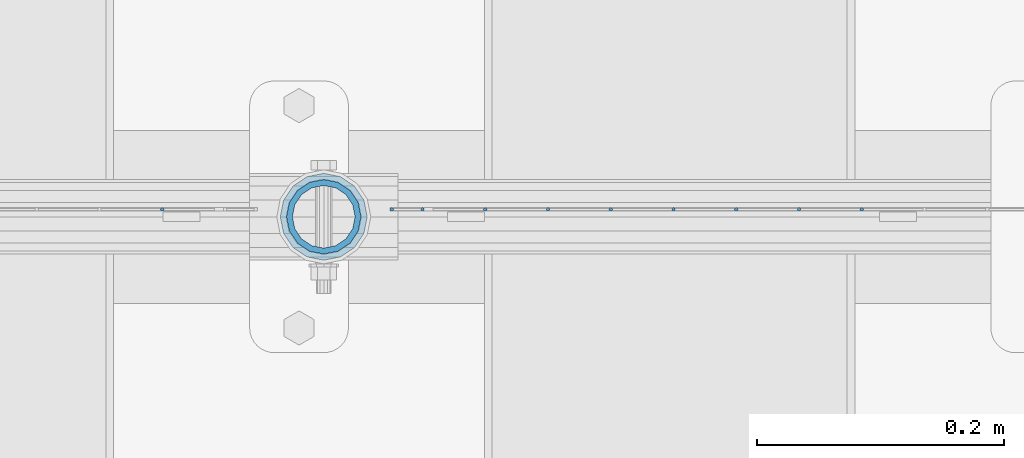
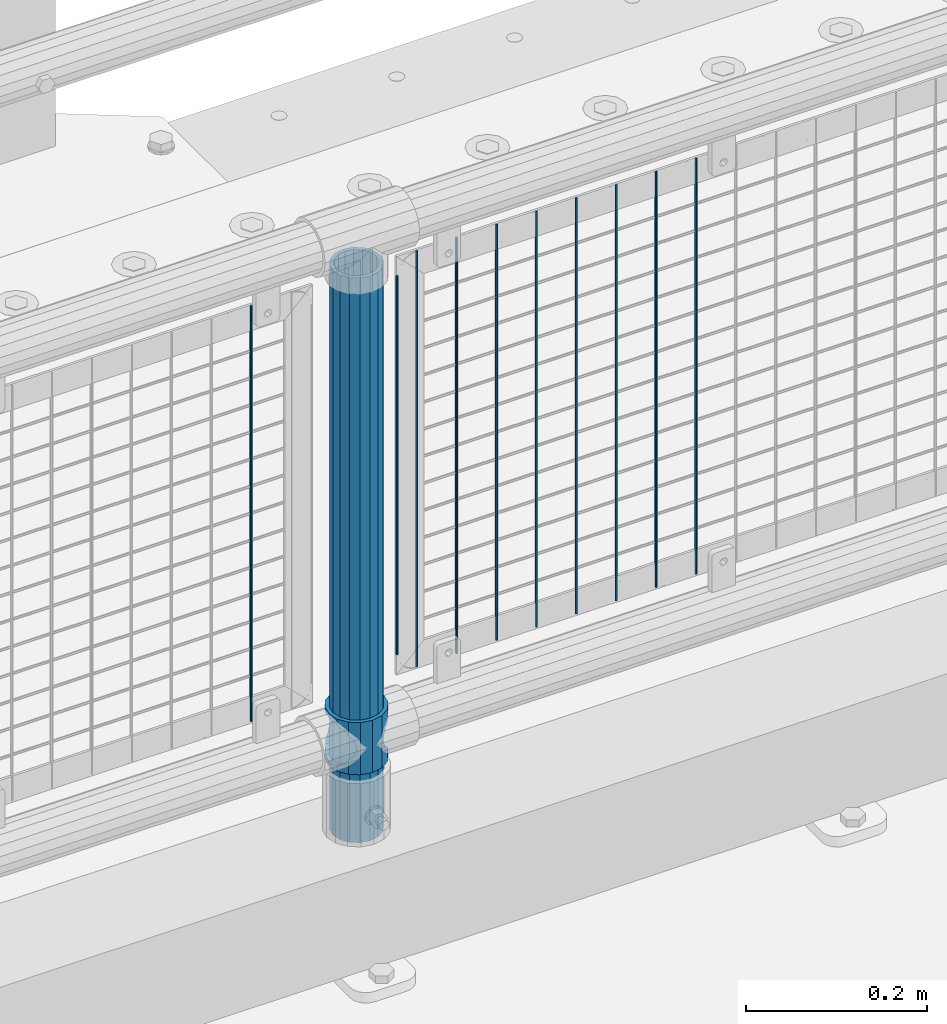
# One storey, part 72 of 242: 12 columns.
"""IFC2X3 building model written with IfcOpenShell, lengths in millimetres."""

from ifc_helpers import new_model, si_unit, frame, origin_with_axes, place, context, subcontext, project, spatial, faceted_brep, material, type_object, element, save


model = new_model("IFC2X3")

# Units and contexts
model_context = context("Model", 3, precision=1e-05, world=origin_with_axes())
body_context = subcontext(model_context, "Body", "Model", "MODEL_VIEW")
ifc_project = project(units=[si_unit("LENGTHUNIT", "METRE", prefix="MILLI"), si_unit("AREAUNIT", "SQUARE_METRE"), si_unit("VOLUMEUNIT", "CUBIC_METRE"), si_unit("MASSUNIT", "GRAM", prefix="KILO"), si_unit("TIMEUNIT", "SECOND"), si_unit("PLANEANGLEUNIT", "RADIAN"), si_unit("SOLIDANGLEUNIT", "STERADIAN"), si_unit("THERMODYNAMICTEMPERATUREUNIT", "DEGREE_CELSIUS"), si_unit("LUMINOUSINTENSITYUNIT", "LUMEN")], contexts=[model_context])

# Site, building, storey
site_placement = place(None, origin_with_axes())
site = spatial("IfcSite", under=ifc_project, at=site_placement, CompositionType="ELEMENT")
building_placement = place(site_placement, origin_with_axes())
building = spatial("IfcBuilding", under=site, at=building_placement, Name="Standard", CompositionType="ELEMENT")
storey_placement = place(building_placement, origin_with_axes())
storey = spatial("IfcBuildingStorey", under=building, at=storey_placement, Name="Undefined", CompositionType="ELEMENT", Elevation=0.0)

# Columns
ifc_material_1 = material()
column_type_1 = type_object("IfcColumnType", PredefinedType="NOTDEFINED")
column_1_placement = place(storey_placement, frame((-36930.0, -19335.5, 168.02), z_axis=(-1.0, 0.0, 0.0), x_axis=(0.0, 0.0, 1.0)))
element("IfcColumn", 1, at=column_1_placement, inside=storey, type_object=column_type_1, material=ifc_material_1, context=body_context, shape_type="Brep", body=[
    faceted_brep([(0.0, -25.3499999999985, 0.0), (0.0, -23.4203461491597, 9.70102501045403), (760.0, -23.4203461491597, 9.70102501045403), (760.0, -25.3499999999985, 0.0), (0.0, -17.9251569030785, 17.9251569030785), (760.0, -17.9251569030785, 17.9251569030785), (0.0, -9.70102501045403, 23.4203461491597), (760.0, -9.70102501045403, 23.4203461491597), (0.0, 0.0, 25.3499999999985), (760.0, 0.0, 25.3499999999985), (0.0, 9.70102501045403, 23.4203461491597), (760.0, 9.70102501045403, 23.4203461491597), (0.0, 17.9251569030785, 17.9251569030785), (760.0, 17.9251569030785, 17.9251569030785), (0.0, 23.4203461491597, 9.70102501045403), (760.0, 23.4203461491597, 9.70102501045403), (0.0, 25.3499999999985, 0.0), (760.0, 25.3499999999985, 0.0), (0.0, 23.4203461491597, -9.70102501045403), (760.0, 23.4203461491597, -9.70102501045403), (0.0, 17.9251569030785, -17.9251569030785), (760.0, 17.9251569030785, -17.9251569030785), (0.0, 9.70102501045403, -23.4203461491597), (760.0, 9.70102501045403, -23.4203461491597), (0.0, 0.0, -25.3499999999985), (760.0, 0.0, -25.3499999999985), (0.0, -9.70102501045403, -23.4203461491597), (760.0, -9.70102501045403, -23.4203461491597), (0.0, -17.9251569030785, -17.9251569030785), (760.0, -17.9251569030785, -17.9251569030785), (0.0, -23.4203461491597, -9.70102501045403), (760.0, -23.4203461491597, -9.70102501045403), (0.0, -30.1500000000015, 0.0), (0.0, -27.8549679052157, -11.5379054858058), (760.0, -27.8549679052157, -11.5379054858058), (760.0, -30.1500000000015, 0.0), (0.0, -21.3192694527752, -21.3192694527752), (760.0, -21.3192694527752, -21.3192694527752), (0.0, -11.5379054858058, -27.8549679052157), (760.0, -11.5379054858058, -27.8549679052157), (0.0, 0.0, -30.1500000000015), (760.0, 0.0, -30.1500000000015), (0.0, 11.5379054858058, -27.8549679052157), (760.0, 11.5379054858058, -27.8549679052157), (0.0, 21.3192694527752, -21.3192694527752), (760.0, 21.3192694527752, -21.3192694527752), (0.0, 27.8549679052157, -11.5379054858058), (760.0, 27.8549679052157, -11.5379054858058), (0.0, 30.1500000000015, 0.0), (760.0, 30.1500000000015, 0.0), (0.0, 27.8549679052157, 11.5379054858058), (760.0, 27.8549679052157, 11.5379054858058), (0.0, 21.3192694527752, 21.3192694527752), (760.0, 21.3192694527752, 21.3192694527752), (0.0, 11.5379054858058, 27.8549679052157), (760.0, 11.5379054858058, 27.8549679052157), (0.0, 0.0, 30.1500000000015), (760.0, 0.0, 30.1500000000015), (0.0, -11.5379054858058, 27.8549679052157), (760.0, -11.5379054858058, 27.8549679052157), (0.0, -21.3192694527752, 21.3192694527752), (760.0, -21.3192694527752, 21.3192694527752), (0.0, -27.8549679052157, 11.5379054858058), (760.0, -27.8549679052157, 11.5379054858058)], [[[0, 1, 2, 3]], [[1, 4, 5, 2]], [[4, 6, 7, 5]], [[6, 8, 9, 7]], [[8, 10, 11, 9]], [[10, 12, 13, 11]], [[12, 14, 15, 13]], [[14, 16, 17, 15]], [[16, 18, 19, 17]], [[18, 20, 21, 19]], [[20, 22, 23, 21]], [[22, 24, 25, 23]], [[24, 26, 27, 25]], [[26, 28, 29, 27]], [[28, 30, 31, 29]], [[30, 0, 3, 31]], [[32, 33, 34, 35]], [[33, 36, 37, 34]], [[36, 38, 39, 37]], [[38, 40, 41, 39]], [[40, 42, 43, 41]], [[42, 44, 45, 43]], [[44, 46, 47, 45]], [[46, 48, 49, 47]], [[48, 50, 51, 49]], [[50, 52, 53, 51]], [[52, 54, 55, 53]], [[54, 56, 57, 55]], [[56, 58, 59, 57]], [[58, 60, 61, 59]], [[60, 62, 63, 61]], [[62, 32, 35, 63]], [[37, 39, 41, 43, 45, 47, 49, 51, 53, 55, 57, 59, 61, 63, 35, 34], [5, 7, 9, 11, 13, 15, 17, 19, 21, 23, 25, 27, 29, 31, 3, 2]], [[62, 60, 58, 56, 54, 52, 50, 48, 46, 44, 42, 40, 38, 36, 33, 32], [30, 28, 26, 24, 22, 20, 18, 16, 14, 12, 10, 8, 6, 4, 1, 0]]]),
])
ifc_material_2 = material(Name="Misc_Undefined")
column_type_2 = type_object("IfcColumnType", PredefinedType="NOTDEFINED")
column_2_placement = place(storey_placement, frame((-36930.0, -19335.5, 263.02), z_axis=(-1.0, 0.0, 0.0), x_axis=(0.0, 0.0, 1.0)))
element("IfcColumn", 2, at=column_2_placement, inside=storey, type_object=column_type_2, material=ifc_material_2, context=body_context, shape_type="Brep", body=[
    faceted_brep([(63.1897438117172, 11.614442172282, -32.8397438117245), (63.1897438117172, 11.614442172282, -28.0397438117143), (56.6106908090114, 21.46069080901, -21.4606908090136), (56.6106908090114, 21.46069080901, -27.1226768591077), (61.9623795176744, 13.4513226476338, -32.4743655677739), (46.7644421722801, 28.0397438117179, -11.6144421722784), (46.7644421722801, 28.0397438117179, -20.0882031229849), (51.5310424080006, 24.8548033587067, -24.8548033587067), (35.1500000000015, 30.35, 0.0), (35.1499999999996, 30.3499999999985, -16.6306603983685), (23.5355578277192, 28.0397438117179, -11.6144421722784), (23.5355578277192, 28.0397438117179, -20.0882031229849), (18.7689575919987, 24.8548033587067, -24.8548033587067), (13.6893091909879, 21.46069080901, -21.4606908090136), (13.6893091909879, 21.46069080901, -27.1226768591077), (8.33762048232262, 13.4513226476338, -32.4743655677739), (7.11025618828211, 11.614442172282, -28.0397438117143), (7.11025618828211, 11.614442172282, -32.8397438117245), (4.79999999999961, 0.0, -30.3499999999985), (4.79999999999961, 0.0, -35.1500000000015), (7.11025618828211, -11.614442172282, -28.0397438117143), (7.11025618828211, -11.614442172282, -32.8397438117172), (13.6893091909879, -21.46069080901, -21.4606908090136), (13.6893091909879, -21.46069080901, -27.1226768591077), (8.33762048232484, -13.4513226476338, -32.4743655677739), (23.5355578277191, -28.0397438117179, -11.6144421722784), (23.5355578277191, -28.0397438117179, -20.0882031229921), (18.7689575919975, -24.8548033587067, -24.8548033587067), (35.1500000000015, -30.35, 0.0), (35.1499999999996, -30.3499999999985, -16.6306603983758), (46.7644421722801, -28.0397438117179, -11.6144421722784), (46.7644421722801, -28.0397438117179, -20.0882031229921), (51.5310424079973, -24.8548033587067, -24.8548033587067), (56.6106908090114, -21.46069080901, -21.4606908090136), (56.6106908090114, -21.46069080901, -27.1226768591077), (61.9623795176767, -13.4513226476338, -32.4743655677739), (63.1897438117172, -11.614442172282, -28.0397438117143), (63.1897438117172, -11.614442172282, -32.8397438117172), (65.4999999999997, 0.0, -30.3499999999985), (65.4999999999997, 0.0, -35.1500000000015), (0.0, -28.0397438117179, -11.6144421722784), (0.0, -30.3499999999985, 0.0), (0.0, -21.46069080901, -21.4606908090136), (0.0, -11.614442172282, -28.0397438117143), (0.0, 0.0, -30.3499999999985), (0.0, 11.614442172282, -28.0397438117143), (0.0, 21.46069080901, -21.4606908090136), (0.0, 28.0397438117179, -11.6144421722784), (0.0, 30.3499999999985, 0.0), (0.0, 28.0397438117179, 11.6144421722784), (23.5355578277192, 28.0397438117179, 11.614442172282), (0.0, 21.46069080901, 21.4606908090136), (13.6893091909879, 21.46069080901, 21.46069080901), (0.0, 11.614442172282, 28.0397438117143), (7.11025618828211, 11.614442172282, 28.0397438117179), (0.0, 0.0, 30.3499999999985), (4.79999999999961, 0.0, 30.3499999999985), (0.0, -11.614442172282, 28.0397438117143), (7.11025618828205, -11.614442172282, 28.0397438117179), (0.0, -21.46069080901, 21.4606908090136), (13.6893091909879, -21.46069080901, 21.46069080901), (0.0, -28.0397438117179, 11.6144421722784), (23.5355578277191, -28.0397438117179, 11.614442172282), (0.0, -32.4743655677703, 13.4513226476338), (0.0, -35.1500000000015, 0.0), (70.2999999999993, -35.1500000000015, 0.0), (70.2999999999993, -32.4743655677703, 13.4513226476338), (0.0, 13.4513226476338, -32.4743655677739), (0.0, 24.8548033587067, -24.8548033587067), (0.0, 0.0, -35.1500000000015), (0.0, -13.4513226476338, -32.4743655677739), (0.0, -24.8548033587067, -24.8548033587067), (0.0, -24.8548033587067, 24.8548033587067), (0.0, -13.4513226476338, 32.4743655677739), (0.0, 0.0, 35.1500000000015), (0.0, 13.4513226476338, 32.4743655677739), (0.0, 24.8548033587067, 24.8548033587067), (0.0, 32.4743655677703, 13.4513226476338), (0.0, 35.1500000000015, 0.0), (0.0, 32.4743655677703, -13.4513226476338), (0.0, -32.4743655677703, -13.4513226476338), (70.2999999999993, 32.4743655677703, 13.4513226476338), (70.2999999999993, 35.1500000000015, 0.0), (70.2999999999993, 32.4743655677703, -13.4513226476338), (70.2999999999993, 24.8548033587067, -24.8548033587067), (70.2999999999993, 13.4513226476338, -32.4743655677739), (70.2999999999993, 0.0, -35.1500000000015), (70.2999999999993, -13.4513226476338, -32.4743655677739), (70.2999999999993, -24.8548033587067, -24.8548033587067), (70.2999999999993, -32.4743655677703, -13.4513226476338), (70.2999999999993, 28.0397438117179, 11.6144421722784), (70.2999999999993, 21.46069080901, 21.4606908090136), (56.6106908090114, 21.46069080901, 21.46069080901), (46.7644421722801, 28.0397438117179, 11.614442172282), (70.2999999999993, 11.614442172282, 28.0397438117143), (63.1897438117172, 11.614442172282, 28.0397438117179), (70.2999999999993, 0.0, 30.3499999999985), (65.4999999999997, 0.0, 30.3499999999985), (70.2999999999993, -11.614442172282, 28.0397438117143), (63.1897438117172, -11.614442172282, 28.0397438117179), (70.2999999999993, -21.46069080901, 21.4606908090136), (56.6106908090114, -21.46069080901, 21.46069080901), (70.2999999999993, -28.0397438117179, 11.6144421722784), (46.7644421722801, -28.0397438117179, 11.614442172282), (70.2999999999993, -11.614442172282, -28.0397438117143), (70.2999999999993, 0.0, -30.3499999999985), (70.2999999999993, -21.46069080901, -21.4606908090136), (70.2999999999993, -28.0397438117179, -11.6144421722784), (70.2999999999993, -30.3499999999985, 0.0), (70.2999999999993, 24.8548033587067, 24.8548033587067), (70.2999999999993, 13.4513226476338, 32.4743655677739), (70.2999999999993, 0.0, 35.1500000000015), (70.2999999999993, -13.4513226476338, 32.4743655677739), (70.2999999999993, -24.8548033587067, 24.8548033587067), (70.2999999999993, 30.3499999999985, 0.0), (70.2999999999993, 28.0397438117179, -11.6144421722784), (70.2999999999993, 21.46069080901, -21.4606908090136), (70.2999999999993, 11.614442172282, -28.0397438117143), (61.9623795176744, 13.4513226476338, 32.4743655677703), (51.5310424080006, 24.8548033587067, 24.8548033587067), (56.6106908090114, 21.46069080901, 27.1226768591077), (65.4999999999997, 0.0, 35.1500000000015), (63.1897438117172, 11.614442172282, 32.8397438117136), (63.1897438117172, -11.614442172282, 32.8397438117172), (61.9623795176767, -13.4513226476338, 32.4743655677703), (56.6106908090114, -21.46069080901, 27.1226768591077), (51.5310424080038, -24.8548033587067, 24.8548033587067), (18.7689575919954, -24.8548033587067, 24.8548033587067), (46.7644421722801, -28.0397438117179, 20.0882031229885), (35.1499999999996, -30.3499999999985, 16.6306603983685), (23.5355578277191, -28.0397438117179, 20.0882031229885), (8.33762048232484, -13.4513226476338, 32.4743655677703), (13.6893091909879, -21.46069080901, 27.1226768591077), (4.79999999999961, 0.0, 35.1500000000015), (7.11025618828205, -11.614442172282, 32.8397438117172), (7.11025618828211, 11.614442172282, 32.8397438117136), (8.33762048232262, 13.4513226476338, 32.4743655677703), (13.6893091909879, 21.46069080901, 27.1226768591077), (18.768957592002, 24.8548033587067, 24.8548033587067), (23.5355578277192, 28.0397438117179, 20.0882031229812), (35.1499999999996, 30.3499999999985, 16.6306603983721), (46.7644421722801, 28.0397438117179, 20.0882031229812)], [[[0, 1, 2, 3, 4]], [[3, 2, 5, 6, 7]], [[6, 5, 8, 9]], [[9, 8, 10, 11]], [[12, 11, 10, 13, 14]], [[15, 14, 13, 16, 17]], [[17, 16, 18, 19]], [[19, 18, 20, 21]], [[21, 20, 22, 23, 24]], [[23, 22, 25, 26, 27]], [[26, 25, 28, 29]], [[29, 28, 30, 31]], [[32, 31, 30, 33, 34]], [[35, 34, 33, 36, 37]], [[37, 36, 38, 39]], [[39, 38, 1, 0]], [[40, 41, 28, 25]], [[42, 40, 25, 22]], [[43, 42, 22, 20]], [[44, 43, 20, 18]], [[45, 44, 18, 16]], [[46, 45, 16, 13]], [[47, 46, 13, 10]], [[48, 47, 10, 8]], [[49, 48, 8, 50]], [[51, 49, 50, 52]], [[53, 51, 52, 54]], [[55, 53, 54, 56]], [[57, 55, 56, 58]], [[59, 57, 58, 60]], [[61, 59, 60, 62]], [[41, 61, 62, 28]], [[63, 64, 65, 66]], [[67, 68, 12, 14, 15]], [[69, 67, 15, 17, 19]], [[24, 70, 69, 19, 21]], [[27, 71, 70, 24, 23]], [[63, 72, 73, 74, 75, 76, 77, 78, 79, 68, 67, 69, 70, 71, 80, 64], [40, 42, 43, 44, 45, 46, 47, 48, 49, 51, 53, 55, 57, 59, 61, 41]], [[78, 77, 81, 82]], [[79, 78, 82, 83]], [[68, 79, 83, 84, 7, 6, 9, 11, 12]], [[7, 84, 85, 4, 3]], [[4, 85, 86, 39, 0]], [[87, 88, 32, 34, 35]], [[86, 87, 35, 37, 39]], [[29, 31, 32, 88, 89, 80, 71, 27, 26]], [[64, 80, 89, 65]], [[90, 91, 92, 93]], [[91, 94, 95, 92]], [[94, 96, 97, 95]], [[96, 98, 99, 97]], [[98, 100, 101, 99]], [[100, 102, 103, 101]], [[104, 105, 38, 36]], [[106, 104, 36, 33]], [[107, 106, 33, 30]], [[108, 107, 30, 28]], [[102, 108, 28, 103]], [[88, 87, 86, 85, 84, 83, 82, 81, 109, 110, 111, 112, 113, 66, 65, 89], [100, 98, 96, 94, 91, 90, 114, 115, 116, 117, 105, 104, 106, 107, 108, 102]], [[118, 110, 109, 119, 120]], [[121, 111, 110, 118, 122]], [[112, 111, 121, 123, 124]], [[113, 112, 124, 125, 126]], [[127, 72, 63, 66, 113, 126, 128, 129, 130]], [[131, 73, 72, 127, 132]], [[133, 74, 73, 131, 134]], [[75, 74, 133, 135, 136]], [[76, 75, 136, 137, 138]], [[119, 109, 81, 77, 76, 138, 139, 140, 141]], [[92, 120, 119, 141, 93]], [[95, 122, 118, 120, 92]], [[97, 121, 122, 95]], [[99, 123, 121, 97]], [[101, 125, 124, 123, 99]], [[103, 128, 126, 125, 101]], [[28, 129, 128, 103]], [[62, 130, 129, 28]], [[60, 132, 127, 130, 62]], [[58, 134, 131, 132, 60]], [[56, 133, 134, 58]], [[54, 135, 133, 56]], [[52, 137, 136, 135, 54]], [[50, 139, 138, 137, 52]], [[8, 140, 139, 50]], [[93, 141, 140, 8]], [[114, 90, 93, 8]], [[115, 114, 8, 5]], [[116, 115, 5, 2]], [[117, 116, 2, 1]], [[105, 117, 1, 38]]]),
])
column_type_3 = type_object("IfcColumnType", Name="D3", PredefinedType="NOTDEFINED")
for number, where, z_axis, x_axis in (
    (3, (-36494.449, -19329.5, 353.02), (-1.0, 0.0, 0.0), (0.0, 0.0, 1.0)),
    (4, (-36545.242, -19329.5, 353.02), (-1.0, 0.0, 0.0), (0.0, 0.0, 1.0)),
    (5, (-36596.035, -19329.5, 353.02), (-1.0, 0.0, 0.0), (0.0, 0.0, 1.0)),
    (6, (-36646.828, -19329.5, 353.02), (-1.0, 0.0, 0.0), (0.0, 0.0, 1.0)),
    (7, (-36697.621, -19329.5, 353.02), (-1.0, 0.0, 0.0), (0.0, 0.0, 1.0)),
    (8, (-36748.414, -19329.5, 353.02), (-1.0, 0.0, 0.0), (0.0, 0.0, 1.0)),
    (9, (-36799.207, -19329.5, 353.02), (-1.0, 0.0, 0.0), (0.0, 0.0, 1.0)),
):
    element("IfcColumn", number, at=place(storey_placement, frame(where, z_axis=z_axis, x_axis=x_axis)), inside=storey, type_object=column_type_3, material=ifc_material_2, ObjectType="D3", context=body_context, shape_type="Brep", body=[
        faceted_brep([(0.0, -1.50000000000364, 0.0), (-3.63797880709171e-12, -0.750000000003638, -1.29903810567669), (560.0, -0.75, -1.29903810567703), (560.0, -1.5, 0.0), (0.0, 0.749999999996362, -1.29903810567669), (560.0, 0.75, -1.29903810567703), (-3.63797880709171e-12, 1.49999999999636, 0.0), (560.0, 1.5, 0.0), (0.0, 0.749999999996362, 1.29903810567669), (560.0, 0.75, 1.29903810567703), (-3.63797880709171e-12, -0.750000000003638, 1.29903810567669), (560.0, -0.75, 1.29903810567703)], [[[0, 1, 2, 3]], [[1, 4, 5, 2]], [[4, 6, 7, 5]], [[6, 8, 9, 7]], [[8, 10, 11, 9]], [[10, 0, 3, 11]], [[5, 7, 9, 11, 3, 2]], [[10, 8, 6, 4, 1, 0]]]),
    ])
column_3_placement = place(storey_placement, frame((-36875.0, -19329.5, 378.02), z_axis=(-1.0, 0.0, 0.0), x_axis=(0.0, 0.0, 1.0)))
element("IfcColumn", 10, at=column_3_placement, inside=storey, type_object=column_type_3, material=ifc_material_2, ObjectType="D3", context=body_context, shape_type="Brep", body=[
    faceted_brep([(0.0, -1.50000000000364, 0.0), (-3.63797880709171e-12, -0.750000000003638, -1.29903810567669), (510.0, -0.75, -1.29903810567703), (510.0, -1.5, 0.0), (0.0, 0.749999999996362, -1.29903810567669), (510.0, 0.75, -1.29903810567703), (-3.63797880709171e-12, 1.49999999999636, 0.0), (510.0, 1.5, 0.0), (0.0, 0.749999999996362, 1.29903810567669), (510.0, 0.75, 1.29903810567703), (-3.63797880709171e-12, -0.750000000003638, 1.29903810567669), (510.0, -0.75, 1.29903810567703)], [[[0, 1, 2, 3]], [[1, 4, 5, 2]], [[4, 6, 7, 5]], [[6, 8, 9, 7]], [[8, 10, 11, 9]], [[10, 0, 3, 11]], [[5, 7, 9, 11, 3, 2]], [[10, 8, 6, 4, 1, 0]]]),
])
for number, where, z_axis, x_axis in (
    (11, (-36850.0, -19329.5, 353.02), (-1.0, 0.0, 0.0), (0.0, 0.0, 1.0)),
    (12, (-37060.796, -19329.5, 353.02), (-1.0, 0.0, 0.0), (0.0, 0.0, 1.0)),
):
    element("IfcColumn", number, at=place(storey_placement, frame(where, z_axis=z_axis, x_axis=x_axis)), inside=storey, type_object=column_type_3, material=ifc_material_2, ObjectType="D3", context=body_context, shape_type="Brep", body=[
        faceted_brep([(0.0, -1.50000000000364, 0.0), (-3.63797880709171e-12, -0.750000000003638, -1.29903810567669), (560.0, -0.75, -1.29903810567703), (560.0, -1.5, 0.0), (0.0, 0.749999999996362, -1.29903810567669), (560.0, 0.75, -1.29903810567703), (-3.63797880709171e-12, 1.49999999999636, 0.0), (560.0, 1.5, 0.0), (0.0, 0.749999999996362, 1.29903810567669), (560.0, 0.75, 1.29903810567703), (-3.63797880709171e-12, -0.750000000003638, 1.29903810567669), (560.0, -0.75, 1.29903810567703)], [[[0, 1, 2, 3]], [[1, 4, 5, 2]], [[4, 6, 7, 5]], [[6, 8, 9, 7]], [[8, 10, 11, 9]], [[10, 0, 3, 11]], [[5, 7, 9, 11, 3, 2]], [[10, 8, 6, 4, 1, 0]]]),
    ])

save(model, "model.ifc")
